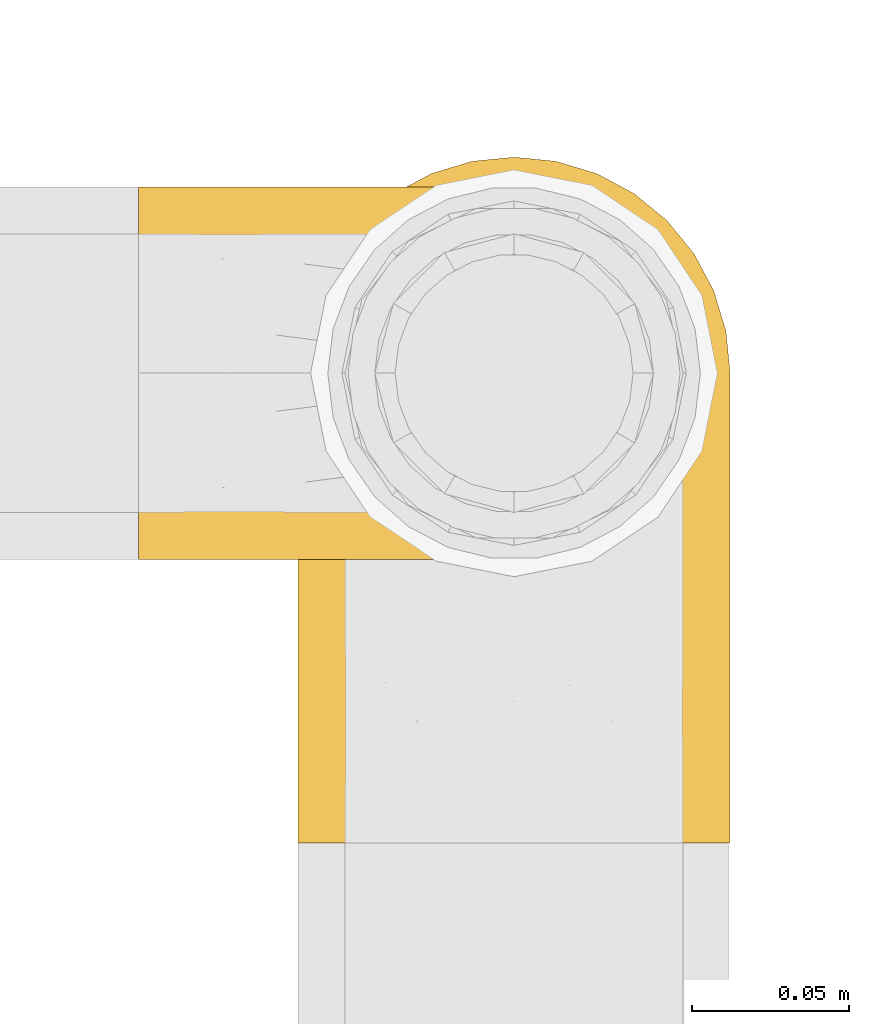
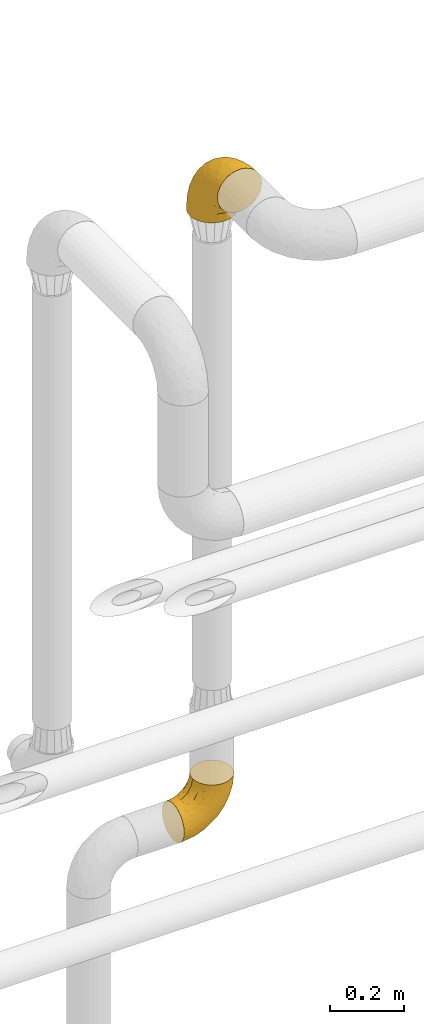
# One storey, part 484 of 827: 2 coverings.
"""IFC2X3 building model written with IfcOpenShell, lengths in millimetres."""

from ifc_helpers import new_model, entity, si_unit, converted_unit, derived_unit, direction, frame, origin, place, context, subcontext, project, spatial, faceted_brep, element, save


model = new_model("IFC2X3")

# Units and contexts
model_context = context("Model", 3, precision=0.01, world=origin(), true_north=direction((6.12303176911189e-17, 1.0)))
body_context = subcontext(model_context, "Body", "Model", "MODEL_VIEW")
ifc_project = project(units=[si_unit("LENGTHUNIT", "METRE", prefix="MILLI"), si_unit("AREAUNIT", "SQUARE_METRE"), si_unit("VOLUMEUNIT", "CUBIC_METRE"), converted_unit("PLANEANGLEUNIT", "DEGREE", entity("IfcRatioMeasure", 0.0174532925199433), si_unit("PLANEANGLEUNIT", "RADIAN"), dimensions=[0, 0, 0, 0, 0, 0, 0]), si_unit("MASSUNIT", "GRAM", prefix="KILO"), derived_unit("MASSDENSITYUNIT", [(si_unit("MASSUNIT", "GRAM", prefix="KILO"), 1), (si_unit("LENGTHUNIT", "METRE"), -3)]), derived_unit("MOMENTOFINERTIAUNIT", [(si_unit("LENGTHUNIT", "METRE"), 4)]), si_unit("TIMEUNIT", "SECOND"), si_unit("FREQUENCYUNIT", "HERTZ"), si_unit("THERMODYNAMICTEMPERATUREUNIT", "DEGREE_CELSIUS"), derived_unit("THERMALTRANSMITTANCEUNIT", [(si_unit("MASSUNIT", "GRAM", prefix="KILO"), 1), (si_unit("THERMODYNAMICTEMPERATUREUNIT", "KELVIN"), -1), (si_unit("TIMEUNIT", "SECOND"), -3)]), derived_unit("VOLUMETRICFLOWRATEUNIT", [(si_unit("LENGTHUNIT", "METRE"), 3), (si_unit("TIMEUNIT", "SECOND"), -1)]), derived_unit("MASSFLOWRATEUNIT", [(si_unit("MASSUNIT", "GRAM", prefix="KILO"), 1), (si_unit("TIMEUNIT", "SECOND"), -1)]), derived_unit("ROTATIONALFREQUENCYUNIT", [(si_unit("TIMEUNIT", "SECOND"), -1)]), si_unit("ELECTRICCURRENTUNIT", "AMPERE"), si_unit("ELECTRICVOLTAGEUNIT", "VOLT"), si_unit("POWERUNIT", "WATT"), si_unit("FORCEUNIT", "NEWTON", prefix="KILO"), si_unit("ILLUMINANCEUNIT", "LUX"), si_unit("LUMINOUSFLUXUNIT", "LUMEN"), si_unit("LUMINOUSINTENSITYUNIT", "CANDELA"), derived_unit("USERDEFINED", [(si_unit("MASSUNIT", "GRAM", prefix="KILO"), -1), (si_unit("LENGTHUNIT", "METRE"), -2), (si_unit("TIMEUNIT", "SECOND"), 3), (si_unit("LUMINOUSFLUXUNIT", "LUMEN"), 1)]), derived_unit("LINEARVELOCITYUNIT", [(si_unit("LENGTHUNIT", "METRE"), 1), (si_unit("TIMEUNIT", "SECOND"), -1)]), si_unit("PRESSUREUNIT", "PASCAL"), derived_unit("USERDEFINED", [(si_unit("LENGTHUNIT", "METRE"), -2), (si_unit("MASSUNIT", "GRAM", prefix="KILO"), 1), (si_unit("TIMEUNIT", "SECOND"), -2)]), derived_unit("LINEARFORCEUNIT", [(si_unit("MASSUNIT", "GRAM", prefix="KILO"), 1), (si_unit("LENGTHUNIT", "METRE"), 1), (si_unit("TIMEUNIT", "SECOND"), -2), (si_unit("LENGTHUNIT", "METRE"), -1)]), derived_unit("PLANARFORCEUNIT", [(si_unit("MASSUNIT", "GRAM", prefix="KILO"), 1), (si_unit("LENGTHUNIT", "METRE"), 1), (si_unit("TIMEUNIT", "SECOND"), -2), (si_unit("LENGTHUNIT", "METRE"), -2)])], contexts=[model_context])

# Site, building, storey
site_placement = place(None, origin())
site = spatial("IfcSite", under=ifc_project, at=site_placement, CompositionType="ELEMENT")
building_placement = place(site_placement, origin())
building = spatial("IfcBuilding", under=site, at=building_placement, CompositionType="ELEMENT")
storey_placement = place(building_placement, frame((0.0, 0.0, 28200.0)))
storey = spatial("IfcBuildingStorey", under=building, at=storey_placement, Name="08", CompositionType="ELEMENT", Elevation=28200.0)

# Coverings
covering_1_placement = place(storey_placement, frame((56037.95, 18484.39, 3348.15)))
element("IfcCovering", 1, at=covering_1_placement, inside=storey, Name=":ADSK_", ObjectType=":ADSK_", PredefinedType="INSULATION", context=body_context, shape_type="Brep", body=[
    faceted_brep([(6.85, 178.01, 1.6), (13.23, 189.94, 1.6), (21.81, 200.39, 1.6), (32.27, 208.97, 1.6), (44.2, 215.35, 1.6), (57.14, 219.27, 1.6), (70.6, 220.6, 1.6), (84.06, 219.27, 1.6), (97.01, 215.34, 1.6), (108.94, 208.96, 1.6), (119.39, 200.38, 1.6), (127.97, 189.92, 1.6), (134.35, 177.99, 1.6), (138.27, 165.05, 1.6), (139.6, 151.6, 1.6), (138.27, 138.13, 1.6), (134.34, 125.18, 1.6), (127.96, 113.25, 1.6), (119.38, 102.8, 1.6), (108.92, 94.22, 1.6), (96.99, 87.84, 1.6), (84.05, 83.92, 1.6), (70.6, 82.6, 1.6), (57.13, 83.92, 1.6), (44.18, 87.85, 1.6), (32.25, 94.23, 1.6), (21.8, 102.81, 1.6), (13.22, 113.27, 1.6), (6.84, 125.2, 1.6), (2.92, 138.14, 1.6), (1.6, 151.6, 1.6), (2.92, 165.06, 1.6), (105.1, 1.6, 91.84), (119.39, 1.6, 102.8), (130.35, 1.6, 117.1), (137.24, 1.6, 133.74), (138.27, 1.6, 141.52), (139.6, 1.6, 151.6), (137.24, 1.6, 169.45), (130.35, 1.6, 186.1), (119.39, 1.6, 200.39), (105.1, 1.6, 211.35), (88.45, 1.6, 218.24), (70.6, 1.6, 220.6), (52.74, 1.6, 218.24), (36.1, 1.6, 211.35), (21.8, 1.6, 200.39), (10.84, 1.6, 186.1), (3.95, 1.6, 169.45), (1.6, 1.6, 151.6), (2.92, 1.6, 141.52), (3.95, 1.6, 133.74), (10.84, 1.6, 117.1), (21.8, 1.6, 102.8), (36.1, 1.6, 91.84), (52.74, 1.6, 84.95), (70.6, 1.6, 82.6), (88.45, 1.6, 84.95), (70.6, 96.62, 198.91), (57.71, 80.58, 204.55), (70.6, 50.33, 215.1), (57.42, 43.35, 215.28), (2.77, 149.73, 68.89), (2.49, 159.34, 34.24), (1.6, 146.48, 40.42), (46.03, 58.25, 208.46), (70.6, 138.14, 172.82), (70.6, 172.82, 138.14), (52.64, 154.77, 154.77), (6.21, 166.7, 59.0), (12.12, 180.71, 54.04), (10.13, 49.23, 178.53), (18.74, 69.31, 185.02), (12.09, 93.48, 163.99), (57.58, 117.02, 186.25), (14.14, 139.53, 131.77), (19.17, 112.16, 163.44), (23.87, 148.78, 138.15), (13.43, 164.18, 97.28), (30.42, 46.47, 202.75), (32.79, 132.99, 162.47), (29.22, 96.71, 183.44), (17.05, 30.92, 192.88), (3.38, 104.14, 131.6), (1.6, 107.66, 107.66), (1.6, 92.13, 119.58), (1.6, 76.6, 131.5), (41.22, 196.61, 85.84), (29.9, 181.1, 102.11), (40.99, 172.58, 127.48), (4.23, 41.4, 165.72), (20.37, 185.43, 73.26), (6.47, 78.35, 159.39), (2.66, 68.43, 149.27), (1.6, 58.51, 138.99), (1.6, 40.42, 146.48), (55.63, 185.97, 116.71), (58.16, 203.47, 83.53), (42.7, 113.61, 182.89), (18.67, 194.09, 35.39), (28.63, 201.68, 45.17), (51.92, 212.49, 50.19), (70.6, 215.1, 50.33), (39.74, 207.81, 49.54), (1.6, 149.35, 18.65), (7.31, 140.08, 112.61), (2.67, 128.76, 102.17), (1.6, 138.99, 58.51), (1.6, 131.5, 76.6), (8.54, 113.78, 142.58), (70.6, 198.91, 96.62), (1.6, 119.58, 92.13), (1.6, 29.53, 147.92), (1.6, 18.65, 149.35), (47.0, 80.16, 34.44), (35.17, 89.84, 22.94), (4.37, 29.67, 129.19), (6.32, 122.24, 33.98), (10.5, 105.26, 53.85), (3.03, 125.73, 57.11), (7.91, 71.48, 100.57), (15.11, 58.44, 94.58), (9.59, 51.31, 108.35), (22.45, 97.53, 31.77), (29.36, 86.31, 43.88), (17.92, 88.46, 61.35), (3.64, 66.49, 118.07), (5.52, 45.64, 120.78), (14.14, 109.54, 24.46), (7.86, 98.42, 74.62), (4.0, 89.11, 100.35), (3.22, 110.1, 82.13), (12.8, 24.41, 111.56), (39.36, 40.18, 81.21), (54.7, 25.64, 80.89), (42.09, 18.97, 87.01), (40.4, 74.17, 51.28), (54.92, 48.07, 70.13), (29.61, 74.2, 62.07), (70.6, 32.59, 76.43), (70.6, 58.87, 58.87), (24.3, 31.2, 95.9), (54.37, 66.88, 52.74), (70.6, 76.43, 32.59), (3.1, 135.6, 22.9), (24.37, 57.13, 83.27), (41.71, 60.86, 65.75), (11.22, 81.23, 84.35), (19.46, 74.24, 75.57), (16.17, 41.41, 101.54), (94.11, 67.91, 54.98), (91.99, 53.29, 68.31), (129.24, 107.85, 41.92), (134.37, 122.25, 28.74), (136.94, 119.38, 59.06), (87.68, 36.15, 77.23), (102.85, 47.83, 77.65), (99.73, 23.54, 86.25), (128.39, 24.41, 111.56), (117.3, 34.04, 95.35), (131.6, 51.31, 108.35), (132.63, 101.08, 68.32), (119.98, 91.86, 48.71), (113.23, 67.16, 71.38), (123.33, 61.73, 88.28), (114.09, 49.53, 85.27), (93.17, 83.0, 25.35), (108.22, 85.77, 39.13), (88.12, 19.29, 82.96), (113.21, 79.91, 56.65), (118.0, 98.26, 26.65), (105.52, 90.34, 19.26), (138.09, 135.59, 22.91), (136.83, 29.67, 129.19), (139.6, 10.12, 150.47), (139.6, 40.42, 146.48), (139.6, 18.65, 149.35), (138.26, 55.12, 127.16), (139.6, 58.51, 138.99), (137.51, 73.14, 113.92), (124.08, 83.76, 69.2), (133.32, 80.62, 93.56), (126.5, 109.55, 20.29), (138.28, 131.53, 43.64), (139.6, 146.48, 40.42), (139.6, 149.35, 18.65), (138.27, 109.93, 84.74), (139.6, 131.5, 76.6), (139.6, 119.58, 92.13), (139.6, 107.66, 107.66), (139.6, 138.99, 58.51), (138.01, 94.02, 100.38), (139.6, 92.13, 119.58), (139.6, 76.6, 131.5), (137.93, 103.69, 131.32), (137.78, 131.71, 104.26), (133.93, 137.62, 115.43), (128.21, 170.23, 84.62), (129.81, 181.78, 45.33), (120.83, 185.41, 73.27), (111.3, 181.05, 102.17), (112.57, 201.67, 45.18), (99.98, 196.59, 85.88), (138.49, 32.97, 160.82), (136.86, 166.02, 41.62), (100.19, 172.58, 127.49), (138.49, 149.5, 68.48), (88.55, 71.61, 206.59), (83.26, 38.88, 216.21), (95.93, 35.03, 213.15), (85.56, 185.97, 116.71), (110.51, 52.66, 201.46), (132.77, 48.93, 175.19), (122.53, 194.07, 35.39), (83.61, 117.02, 186.25), (98.49, 113.61, 182.89), (137.55, 71.88, 152.74), (100.17, 66.16, 203.88), (88.55, 154.77, 154.77), (101.55, 144.64, 157.62), (120.69, 168.23, 107.51), (134.57, 159.68, 78.63), (123.89, 36.9, 192.18), (121.98, 79.27, 181.61), (133.25, 82.58, 161.11), (124.07, 116.61, 157.33), (133.63, 113.01, 140.49), (88.33, 201.66, 84.83), (101.66, 210.27, 36.75), (89.29, 212.48, 50.21), (117.33, 148.74, 138.18), (112.95, 115.41, 171.46), (128.06, 145.02, 123.44), (108.06, 88.56, 190.49)], [[[0, 1, 2, 3, 4, 5, 6, 7, 8, 9, 10, 11, 12, 13, 14, 15, 16, 17, 18, 19, 20, 21, 22, 23, 24, 25, 26, 27, 28, 29, 30, 31]], [[32, 33, 34, 35, 36, 37, 38, 39, 40, 41, 42, 43, 44, 45, 46, 47, 48, 49, 50, 51, 52, 53, 54, 55, 56, 57]], [[58, 59, 60]], [[61, 43, 60]], [[62, 63, 64]], [[44, 65, 45]], [[66, 67, 68]], [[69, 70, 0]], [[71, 72, 73]], [[58, 74, 59]], [[75, 76, 77]], [[74, 58, 66]], [[77, 78, 75]], [[79, 46, 45]], [[80, 76, 81]], [[79, 45, 65]], [[47, 46, 82]], [[83, 84, 85, 86]], [[87, 88, 89]], [[49, 48, 90]], [[91, 70, 78]], [[90, 92, 93]], [[93, 86, 94, 95]], [[87, 96, 97]], [[74, 68, 98]], [[78, 70, 69]], [[70, 91, 99]], [[2, 99, 100]], [[4, 101, 5]], [[102, 101, 97]], [[81, 79, 65]], [[3, 100, 103]], [[68, 96, 89]], [[4, 3, 103]], [[59, 61, 60]], [[102, 6, 5]], [[86, 93, 83]], [[99, 2, 1]], [[68, 89, 80]], [[63, 69, 31]], [[63, 30, 104, 64]], [[92, 90, 71]], [[101, 103, 87]], [[69, 0, 31]], [[105, 62, 106]], [[62, 64, 107, 108]], [[88, 100, 91]], [[83, 106, 84]], [[3, 2, 100]], [[109, 83, 92]], [[96, 67, 110]], [[96, 68, 67]], [[106, 108, 111, 84]], [[102, 5, 101]], [[105, 69, 62]], [[90, 95, 112, 113, 49]], [[83, 93, 92]], [[97, 96, 110]], [[89, 96, 87]], [[95, 90, 93]], [[71, 48, 47]], [[48, 71, 90]], [[82, 71, 47]], [[81, 65, 98]], [[82, 79, 72]], [[1, 0, 70]], [[100, 99, 91]], [[70, 99, 1]], [[78, 69, 105]], [[75, 78, 105]], [[88, 78, 77]], [[87, 100, 88]], [[77, 76, 80]], [[78, 88, 91]], [[77, 89, 88]], [[68, 74, 66]], [[59, 98, 65]], [[105, 109, 75]], [[73, 76, 75]], [[75, 109, 73]], [[81, 76, 72]], [[79, 81, 72]], [[81, 98, 80]], [[83, 109, 105]], [[109, 92, 73]], [[68, 80, 98]], [[89, 77, 80]], [[98, 59, 74]], [[59, 65, 61]], [[65, 44, 61]], [[43, 61, 44]], [[71, 73, 92]], [[72, 76, 73]], [[69, 63, 62]], [[30, 63, 31]], [[105, 106, 83]], [[108, 106, 62]], [[79, 82, 46]], [[71, 82, 72]], [[4, 103, 101]], [[100, 87, 103]], [[102, 97, 110]], [[87, 97, 101]], [[24, 114, 115]], [[116, 112, 95]], [[116, 51, 112]], [[117, 118, 119]], [[52, 51, 116]], [[120, 121, 122]], [[123, 124, 125]], [[94, 126, 127]], [[117, 27, 128]], [[129, 130, 131]], [[124, 123, 115]], [[53, 52, 132]], [[133, 134, 135]], [[84, 131, 130]], [[114, 136, 124]], [[56, 55, 134]], [[134, 133, 137]], [[124, 136, 138]], [[139, 137, 140]], [[54, 53, 141]], [[123, 25, 115]], [[94, 86, 126]], [[26, 128, 27]], [[142, 143, 140]], [[117, 28, 27]], [[123, 26, 25]], [[132, 141, 53]], [[28, 144, 29]], [[144, 104, 29]], [[25, 24, 115]], [[133, 141, 145]], [[118, 128, 123]], [[143, 23, 22]], [[143, 114, 23]], [[141, 133, 135]], [[136, 142, 146]], [[119, 144, 117]], [[137, 142, 140]], [[23, 114, 24]], [[119, 131, 108]], [[118, 117, 128]], [[126, 85, 130]], [[28, 117, 144]], [[128, 26, 123]], [[107, 144, 119]], [[116, 127, 132]], [[107, 119, 108]], [[64, 144, 107]], [[131, 84, 111, 108]], [[119, 118, 131]], [[131, 118, 129]], [[125, 118, 123]], [[138, 146, 145]], [[147, 120, 130]], [[120, 126, 130]], [[114, 124, 115]], [[124, 138, 125]], [[148, 138, 145]], [[129, 125, 147]], [[116, 132, 52]], [[132, 122, 149]], [[121, 149, 122]], [[125, 148, 147]], [[134, 137, 139]], [[133, 145, 146]], [[146, 142, 137]], [[143, 142, 114]], [[133, 146, 137]], [[136, 146, 138]], [[56, 134, 139]], [[134, 55, 135]], [[55, 54, 135]], [[141, 135, 54]], [[104, 144, 64]], [[104, 30, 29]], [[142, 136, 114]], [[50, 49, 113, 112, 51]], [[116, 95, 94]], [[125, 129, 118]], [[130, 129, 147]], [[147, 148, 121]], [[126, 120, 122]], [[127, 126, 122]], [[138, 148, 125]], [[147, 121, 120]], [[149, 145, 141]], [[145, 149, 121]], [[132, 149, 141]], [[132, 127, 122]], [[94, 127, 116]], [[85, 126, 86]], [[85, 84, 130]], [[121, 148, 145]], [[140, 150, 151]], [[152, 153, 154]], [[155, 156, 157]], [[158, 159, 160]], [[152, 161, 162]], [[163, 164, 165]], [[166, 167, 150]], [[155, 168, 139]], [[167, 162, 169]], [[170, 167, 171]], [[15, 172, 16]], [[155, 151, 156]], [[34, 173, 35]], [[174, 37, 36, 35, 175, 176]], [[143, 21, 166]], [[34, 33, 158]], [[143, 150, 140]], [[173, 177, 178]], [[33, 32, 159]], [[166, 150, 143]], [[160, 179, 177]], [[143, 22, 21]], [[161, 180, 162]], [[179, 160, 181]], [[171, 166, 20]], [[32, 57, 157]], [[20, 166, 21]], [[17, 182, 18]], [[18, 170, 19]], [[153, 17, 16]], [[161, 152, 154]], [[183, 172, 184]], [[170, 162, 167]], [[153, 152, 182]], [[181, 164, 180]], [[180, 161, 181]], [[182, 170, 18]], [[184, 172, 185]], [[172, 15, 185]], [[157, 159, 32]], [[164, 163, 180]], [[186, 187, 188, 189]], [[20, 19, 171]], [[158, 173, 34]], [[183, 153, 172]], [[170, 171, 19]], [[166, 171, 167]], [[190, 187, 183, 184]], [[153, 16, 172]], [[183, 187, 154]], [[139, 168, 56]], [[157, 156, 165]], [[153, 182, 17]], [[170, 182, 152]], [[168, 155, 157]], [[140, 155, 139]], [[154, 186, 161]], [[160, 159, 164]], [[191, 161, 186]], [[191, 192, 179]], [[187, 186, 154]], [[191, 186, 189]], [[159, 158, 33]], [[173, 158, 160]], [[160, 164, 181]], [[165, 164, 159]], [[156, 150, 163]], [[169, 150, 167]], [[15, 14, 185]], [[152, 162, 170]], [[169, 180, 163]], [[180, 169, 162]], [[150, 169, 163]], [[154, 153, 183]], [[179, 181, 191]], [[177, 179, 193]], [[178, 175, 173]], [[160, 177, 173]], [[177, 193, 178]], [[161, 191, 181]], [[140, 151, 155]], [[150, 156, 151]], [[175, 35, 173]], [[157, 57, 168]], [[56, 168, 57]], [[157, 165, 159]], [[163, 165, 156]], [[192, 191, 189]], [[192, 193, 179]], [[194, 195, 196]], [[197, 198, 199]], [[200, 201, 202]], [[203, 37, 174, 176, 175]], [[198, 204, 12]], [[200, 202, 205]], [[206, 187, 190, 184]], [[189, 195, 194]], [[58, 60, 207]], [[10, 9, 201]], [[43, 42, 208]], [[209, 207, 208]], [[67, 210, 110]], [[211, 41, 40]], [[205, 202, 210]], [[203, 212, 38]], [[213, 198, 11]], [[214, 207, 215]], [[216, 175, 178, 193]], [[207, 209, 217]], [[218, 219, 205]], [[200, 220, 199]], [[195, 206, 221]], [[198, 221, 204]], [[210, 67, 218]], [[222, 40, 39]], [[14, 13, 204]], [[221, 206, 204]], [[198, 12, 11]], [[221, 197, 196]], [[66, 214, 218]], [[223, 224, 225]], [[203, 175, 216]], [[195, 189, 188, 187]], [[194, 226, 216]], [[213, 201, 199]], [[58, 214, 66]], [[67, 66, 218]], [[110, 210, 227]], [[213, 11, 10]], [[202, 201, 228]], [[7, 102, 229]], [[6, 102, 7]], [[230, 231, 225]], [[231, 219, 215]], [[7, 229, 8]], [[228, 8, 229]], [[38, 212, 39]], [[227, 102, 110]], [[225, 232, 230]], [[9, 8, 228]], [[40, 222, 211]], [[41, 209, 42]], [[223, 231, 233]], [[211, 217, 209]], [[205, 210, 218]], [[229, 227, 202]], [[226, 224, 216]], [[222, 212, 223]], [[201, 213, 10]], [[198, 213, 199]], [[219, 218, 215]], [[200, 199, 201]], [[205, 230, 200]], [[220, 200, 230]], [[207, 214, 58]], [[218, 214, 215]], [[233, 215, 217]], [[230, 205, 219]], [[225, 231, 223]], [[230, 219, 231]], [[224, 223, 212]], [[232, 225, 226]], [[196, 232, 226]], [[220, 197, 199]], [[230, 232, 220]], [[232, 196, 197]], [[232, 197, 220]], [[198, 197, 221]], [[212, 222, 39]], [[211, 222, 223]], [[187, 206, 195]], [[204, 184, 185, 14]], [[184, 204, 206]], [[204, 13, 12]], [[211, 209, 41]], [[208, 207, 60]], [[43, 208, 60]], [[42, 209, 208]], [[233, 217, 211]], [[215, 207, 217]], [[223, 233, 211]], [[215, 233, 231]], [[212, 203, 216]], [[37, 203, 38]], [[216, 193, 194]], [[194, 193, 192, 189]], [[202, 228, 229]], [[9, 228, 201]], [[227, 229, 102]], [[210, 202, 227]], [[225, 224, 226]], [[212, 216, 224]], [[194, 196, 226]], [[221, 196, 195]]]),
])
covering_2_placement = place(storey_placement, frame((55986.95, 18574.89, 1312.79)))
element("IfcCovering", 2, at=covering_2_placement, inside=storey, Name=":ADSK_", ObjectType=":ADSK_", PredefinedType="INSULATION", context=body_context, shape_type="Brep", body=[
    faceted_brep([(1.6, 119.1, 47.85), (1.6, 114.7, 35.28), (1.6, 107.61, 23.99), (1.6, 98.19, 14.57), (1.6, 86.9, 7.48), (1.6, 74.32, 3.08), (1.6, 61.1, 1.6), (1.6, 47.85, 3.09), (1.6, 35.28, 7.49), (1.6, 23.99, 14.58), (1.6, 14.57, 24.0), (1.6, 7.48, 35.29), (1.6, 3.08, 47.87), (1.6, 1.6, 61.1), (1.6, 3.09, 74.34), (1.6, 7.49, 86.92), (1.6, 14.58, 98.2), (1.6, 24.0, 107.62), (1.6, 35.29, 114.71), (1.6, 47.87, 119.11), (1.6, 61.1, 120.6), (1.6, 74.34, 119.1), (1.6, 86.92, 114.7), (1.6, 98.2, 107.61), (1.6, 107.62, 98.19), (1.6, 114.71, 86.9), (1.6, 119.11, 74.32), (1.6, 120.6, 61.1), (64.12, 45.7, 181.1), (70.07, 31.35, 181.1), (79.52, 19.02, 181.1), (91.85, 9.57, 181.1), (106.2, 3.62, 181.1), (121.6, 1.6, 181.1), (137.0, 3.62, 181.1), (151.35, 9.57, 181.1), (163.67, 19.02, 181.1), (173.12, 31.35, 181.1), (179.07, 45.7, 181.1), (181.1, 61.1, 181.1), (179.07, 76.5, 181.1), (173.12, 90.85, 181.1), (163.67, 103.17, 181.1), (151.35, 112.62, 181.1), (137.0, 118.57, 181.1), (121.6, 120.6, 181.1), (106.2, 118.57, 181.1), (91.85, 112.62, 181.1), (79.52, 103.17, 181.1), (70.07, 90.85, 181.1), (64.12, 76.5, 181.1), (62.1, 61.1, 181.1), (166.85, 95.88, 149.36), (171.8, 82.3, 137.95), (156.7, 94.1, 112.73), (175.89, 71.89, 142.53), (174.98, 61.1, 134.64), (34.39, 110.03, 30.78), (141.86, 80.11, 74.16), (157.05, 61.1, 91.35), (128.52, 61.1, 54.17), (125.77, 115.76, 109.16), (142.49, 113.03, 132.51), (137.62, 106.83, 100.6), (133.72, 118.0, 143.49), (116.57, 119.56, 118.25), (116.34, 91.22, 53.89), (137.54, 97.67, 84.22), (160.1, 83.16, 106.32), (166.8, 71.84, 113.45), (154.26, 106.27, 137.68), (48.05, 61.1, 7.71), (44.99, 79.29, 9.86), (75.77, 89.43, 25.56), (109.34, 76.37, 40.03), (78.35, 73.84, 20.36), (96.98, 118.7, 85.71), (106.86, 113.14, 75.88), (67.36, 114.84, 51.26), (49.85, 119.09, 56.83), (72.13, 120.6, 84.01), (98.68, 120.6, 110.56), (107.2, 120.6, 127.29), (115.72, 120.6, 144.01), (91.35, 61.1, 25.64), (45.24, 101.09, 22.95), (73.45, 106.71, 40.15), (33.95, 91.36, 12.95), (32.97, 116.15, 42.03), (16.23, 120.6, 63.41), (38.68, 120.6, 66.97), (74.48, 98.77, 31.89), (85.4, 120.6, 97.29), (115.39, 104.27, 67.3), (55.4, 120.6, 75.49), (119.28, 120.6, 166.46), (85.98, 114.26, 141.36), (71.16, 113.3, 121.72), (70.35, 106.08, 138.16), (103.0, 118.29, 159.88), (94.6, 119.17, 128.08), (55.86, 102.39, 126.23), (81.81, 119.07, 110.87), (60.95, 74.66, 162.96), (52.54, 72.06, 146.61), (57.49, 61.1, 157.94), (24.83, 107.18, 102.08), (37.73, 103.18, 112.03), (50.74, 111.64, 107.36), (87.65, 111.23, 162.91), (74.24, 101.44, 157.88), (15.74, 82.78, 118.07), (20.12, 95.99, 111.72), (61.93, 88.46, 151.58), (65.86, 85.34, 167.61), (40.95, 75.22, 132.93), (44.38, 61.1, 138.32), (38.05, 116.35, 90.2), (55.63, 119.46, 87.09), (56.15, 116.78, 98.46), (31.75, 85.13, 122.87), (49.11, 89.52, 132.83), (20.72, 119.0, 76.52), (32.8, 94.63, 117.49), (18.32, 113.92, 90.0), (24.08, 73.67, 123.48), (24.75, 61.1, 125.2), (70.12, 119.4, 97.44), (61.67, 97.35, 139.94), (41.55, 119.56, 79.72), (96.92, 117.72, 145.56), (81.07, 108.82, 152.47), (70.33, 16.12, 138.17), (55.85, 19.81, 126.24), (71.15, 8.9, 121.74), (20.12, 26.21, 111.73), (24.84, 15.02, 102.09), (61.65, 24.86, 139.94), (38.08, 5.84, 90.22), (41.53, 2.63, 79.72), (55.63, 2.73, 87.08), (40.93, 46.99, 132.91), (60.95, 47.54, 162.97), (65.86, 36.85, 167.61), (87.65, 10.96, 162.91), (81.07, 13.37, 152.47), (85.98, 7.93, 141.36), (94.6, 3.02, 128.08), (84.2, 2.89, 112.07), (98.68, 1.6, 110.56), (103.0, 3.9, 159.88), (119.28, 1.6, 166.46), (40.95, 26.96, 121.68), (31.73, 37.08, 122.86), (74.24, 20.75, 157.88), (50.74, 10.56, 107.38), (52.54, 50.11, 146.61), (37.73, 19.02, 112.05), (24.06, 48.54, 123.48), (68.67, 3.81, 101.72), (18.33, 8.27, 90.01), (96.92, 4.47, 145.56), (15.72, 39.43, 118.07), (20.72, 3.19, 76.53), (49.08, 32.68, 132.81), (38.68, 1.6, 66.97), (16.23, 1.6, 63.41), (55.4, 1.6, 75.49), (51.76, 5.87, 97.07), (85.4, 1.6, 97.29), (115.72, 1.6, 144.01), (107.2, 1.6, 127.29), (72.13, 1.6, 84.01), (61.93, 33.73, 151.59), (156.7, 28.09, 112.73), (166.85, 26.31, 149.36), (154.26, 15.92, 137.68), (142.49, 9.16, 132.51), (175.89, 50.3, 142.53), (171.8, 39.89, 137.95), (166.8, 50.35, 113.45), (116.57, 2.63, 118.25), (137.62, 15.36, 100.6), (109.34, 45.82, 40.03), (116.34, 30.97, 53.89), (75.76, 32.75, 25.56), (96.98, 3.49, 85.71), (133.72, 4.19, 143.49), (160.1, 39.03, 106.32), (78.71, 44.85, 21.51), (44.98, 42.89, 9.86), (141.86, 42.08, 74.16), (32.97, 6.03, 42.04), (49.86, 3.1, 56.84), (125.77, 6.43, 109.16), (106.86, 9.05, 75.88), (34.39, 12.15, 30.8), (45.23, 21.09, 22.96), (137.54, 24.52, 84.22), (33.95, 30.82, 12.96), (67.37, 7.35, 51.28), (73.45, 15.47, 40.16), (115.39, 17.92, 67.3), (74.47, 23.41, 31.9)], [[[0, 1, 2, 3, 4, 5, 6, 7, 8, 9, 10, 11, 12, 13, 14, 15, 16, 17, 18, 19, 20, 21, 22, 23, 24, 25, 26, 27]], [[28, 29, 30, 31, 32, 33, 34, 35, 36, 37, 38, 39, 40, 41, 42, 43, 44, 45, 46, 47, 48, 49, 50, 51]], [[52, 53, 54]], [[55, 39, 56]], [[57, 2, 1]], [[58, 59, 60]], [[61, 62, 63]], [[64, 61, 65]], [[58, 66, 67]], [[53, 68, 54]], [[41, 40, 53]], [[53, 69, 68]], [[70, 42, 52]], [[42, 41, 52]], [[71, 5, 72]], [[73, 74, 75]], [[43, 70, 62]], [[45, 44, 64]], [[76, 77, 78]], [[79, 80, 76]], [[65, 81, 82, 83]], [[74, 60, 84]], [[85, 2, 57]], [[85, 57, 86]], [[2, 85, 3]], [[42, 70, 43]], [[5, 4, 72]], [[72, 87, 73]], [[4, 3, 87]], [[5, 71, 6]], [[75, 74, 84]], [[64, 62, 61]], [[79, 78, 88]], [[54, 67, 63]], [[74, 58, 60]], [[65, 76, 81]], [[79, 27, 89, 90]], [[75, 71, 72]], [[85, 86, 91]], [[78, 57, 88]], [[56, 69, 55]], [[76, 78, 79]], [[76, 80, 92, 81]], [[77, 76, 61]], [[69, 56, 59]], [[4, 87, 72]], [[91, 66, 73]], [[58, 74, 66]], [[3, 85, 87]], [[73, 87, 85]], [[88, 57, 1]], [[86, 57, 78]], [[77, 86, 78]], [[93, 66, 91]], [[73, 66, 74]], [[67, 93, 63]], [[1, 0, 88]], [[0, 27, 79]], [[0, 79, 88]], [[79, 90, 94, 80]], [[64, 83, 95, 45]], [[76, 65, 61]], [[83, 64, 65]], [[62, 44, 43]], [[62, 64, 44]], [[63, 62, 70]], [[54, 63, 70]], [[63, 93, 77]], [[63, 77, 61]], [[77, 93, 86]], [[67, 54, 68]], [[66, 93, 67]], [[53, 52, 41]], [[70, 52, 54]], [[58, 69, 59]], [[55, 69, 53]], [[69, 58, 68]], [[67, 68, 58]], [[53, 40, 55]], [[39, 55, 40]], [[71, 75, 84]], [[73, 75, 72]], [[91, 86, 93]], [[73, 85, 91]], [[96, 97, 98]], [[83, 99, 95]], [[82, 81, 100]], [[95, 99, 46]], [[101, 98, 97]], [[47, 46, 99]], [[97, 100, 102]], [[103, 104, 105]], [[106, 107, 108]], [[109, 48, 47]], [[48, 110, 49]], [[108, 101, 97]], [[111, 112, 22]], [[51, 50, 103]], [[113, 103, 114]], [[23, 22, 112]], [[115, 116, 104]], [[108, 117, 106]], [[112, 106, 23]], [[94, 118, 80]], [[108, 119, 117]], [[120, 115, 121]], [[112, 107, 106]], [[25, 122, 26]], [[122, 89, 26]], [[101, 123, 121]], [[109, 110, 48]], [[124, 25, 24]], [[125, 20, 126]], [[120, 111, 125]], [[110, 113, 114]], [[127, 97, 102]], [[106, 24, 23]], [[125, 115, 120]], [[111, 22, 21]], [[126, 115, 125]], [[117, 124, 106]], [[110, 98, 128]], [[117, 129, 124]], [[117, 118, 129]], [[100, 97, 96]], [[124, 122, 25]], [[83, 82, 130]], [[99, 130, 109]], [[100, 81, 102]], [[100, 130, 82]], [[130, 100, 96]], [[81, 92, 102]], [[127, 80, 118]], [[21, 20, 125]], [[111, 120, 123]], [[21, 125, 111]], [[115, 126, 116]], [[104, 116, 105]], [[101, 107, 123]], [[104, 121, 115]], [[128, 121, 113]], [[105, 51, 103]], [[121, 104, 113]], [[114, 103, 50]], [[113, 104, 103]], [[106, 124, 24]], [[94, 129, 118]], [[123, 107, 112]], [[101, 108, 107]], [[99, 109, 47]], [[131, 109, 96]], [[89, 122, 90]], [[89, 27, 26]], [[122, 129, 90]], [[97, 127, 119]], [[119, 127, 118]], [[102, 92, 127]], [[90, 129, 94]], [[80, 127, 92]], [[124, 129, 122]], [[117, 119, 118]], [[97, 119, 108]], [[50, 49, 114]], [[110, 114, 49]], [[109, 130, 96]], [[130, 99, 83]], [[128, 98, 101]], [[98, 110, 131]], [[121, 128, 101]], [[110, 128, 113]], [[46, 45, 95]], [[111, 123, 112]], [[121, 123, 120]], [[98, 131, 96]], [[110, 109, 131]], [[132, 133, 134]], [[135, 17, 136]], [[132, 137, 133]], [[138, 139, 140]], [[126, 141, 116]], [[105, 142, 51]], [[16, 136, 17]], [[142, 143, 28]], [[144, 145, 146]], [[147, 148, 149]], [[31, 150, 32]], [[150, 151, 32]], [[135, 152, 153]], [[30, 29, 154]], [[155, 136, 138]], [[31, 30, 144]], [[156, 116, 141]], [[136, 155, 157]], [[126, 158, 141]], [[159, 148, 134]], [[20, 19, 158]], [[156, 142, 105]], [[160, 136, 16]], [[147, 161, 146]], [[135, 18, 17]], [[18, 162, 19]], [[136, 157, 135]], [[146, 145, 132]], [[160, 163, 139]], [[16, 15, 160]], [[15, 14, 163]], [[164, 141, 153]], [[133, 155, 134]], [[152, 135, 157]], [[165, 163, 166]], [[163, 14, 166]], [[162, 135, 153]], [[29, 143, 154]], [[165, 167, 139]], [[162, 158, 19]], [[159, 134, 155]], [[167, 140, 139]], [[140, 168, 138]], [[159, 169, 148]], [[144, 150, 31]], [[161, 170, 150]], [[171, 170, 161]], [[149, 171, 147]], [[134, 147, 146]], [[134, 148, 147]], [[135, 162, 18]], [[169, 159, 172]], [[169, 149, 148]], [[158, 162, 153]], [[158, 153, 141]], [[158, 126, 20]], [[153, 152, 164]], [[116, 156, 105]], [[137, 164, 133]], [[156, 164, 173]], [[164, 156, 141]], [[142, 28, 51]], [[156, 173, 142]], [[143, 142, 173]], [[163, 160, 15]], [[136, 160, 138]], [[155, 133, 157]], [[133, 164, 152]], [[154, 144, 30]], [[144, 146, 161]], [[14, 13, 166]], [[172, 159, 140]], [[140, 167, 172]], [[168, 159, 155]], [[160, 139, 138]], [[165, 139, 163]], [[154, 143, 173]], [[29, 28, 143]], [[171, 161, 147]], [[144, 161, 150]], [[159, 168, 140]], [[155, 138, 168]], [[146, 132, 134]], [[137, 154, 173]], [[154, 137, 132]], [[164, 137, 173]], [[151, 150, 170]], [[151, 33, 32]], [[133, 152, 157]], [[144, 154, 145]], [[132, 145, 154]], [[174, 175, 176]], [[35, 34, 177]], [[178, 179, 180]], [[181, 170, 171, 149]], [[176, 182, 174]], [[183, 184, 185]], [[186, 149, 169, 172]], [[187, 33, 151, 170]], [[179, 188, 180]], [[34, 187, 177]], [[39, 38, 178]], [[189, 185, 190]], [[184, 183, 191]], [[175, 179, 37]], [[38, 37, 179]], [[35, 176, 36]], [[180, 59, 56]], [[192, 193, 12]], [[37, 36, 175]], [[181, 187, 170]], [[181, 186, 194]], [[176, 177, 182]], [[8, 7, 190]], [[194, 186, 195]], [[13, 12, 193]], [[196, 192, 11]], [[10, 9, 197]], [[60, 183, 84]], [[174, 182, 198]], [[197, 196, 10]], [[193, 172, 167, 165]], [[8, 199, 9]], [[189, 183, 185]], [[60, 59, 191]], [[200, 196, 201]], [[190, 199, 8]], [[7, 6, 71]], [[10, 196, 11]], [[202, 203, 184]], [[199, 185, 197]], [[7, 71, 190]], [[183, 60, 191]], [[189, 71, 84]], [[193, 186, 172]], [[200, 201, 195]], [[180, 191, 59]], [[185, 199, 190]], [[197, 9, 199]], [[201, 196, 197]], [[192, 196, 200]], [[203, 201, 197]], [[195, 201, 202]], [[191, 188, 198]], [[202, 201, 203]], [[193, 192, 200]], [[12, 11, 192]], [[186, 193, 200]], [[193, 165, 166, 13]], [[186, 181, 149]], [[187, 181, 194]], [[187, 194, 177]], [[187, 34, 33]], [[194, 195, 182]], [[35, 177, 176]], [[194, 182, 177]], [[182, 202, 198]], [[200, 195, 186]], [[182, 195, 202]], [[202, 184, 198]], [[191, 198, 184]], [[176, 175, 36]], [[179, 175, 174]], [[178, 180, 56]], [[179, 174, 188]], [[198, 188, 174]], [[191, 180, 188]], [[39, 178, 56]], [[38, 179, 178]], [[71, 189, 190]], [[84, 183, 189]], [[197, 185, 203]], [[184, 203, 185]]]),
])

save(model, "model.ifc")
